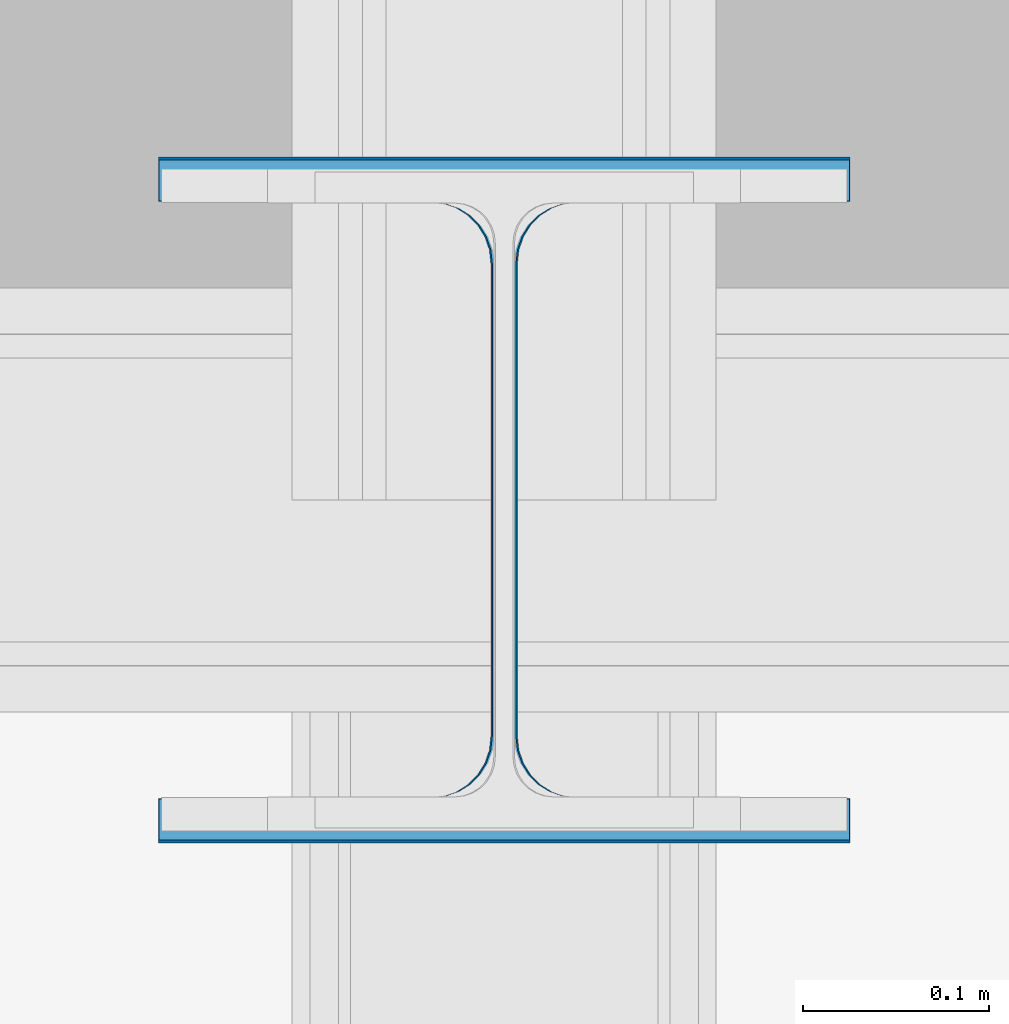
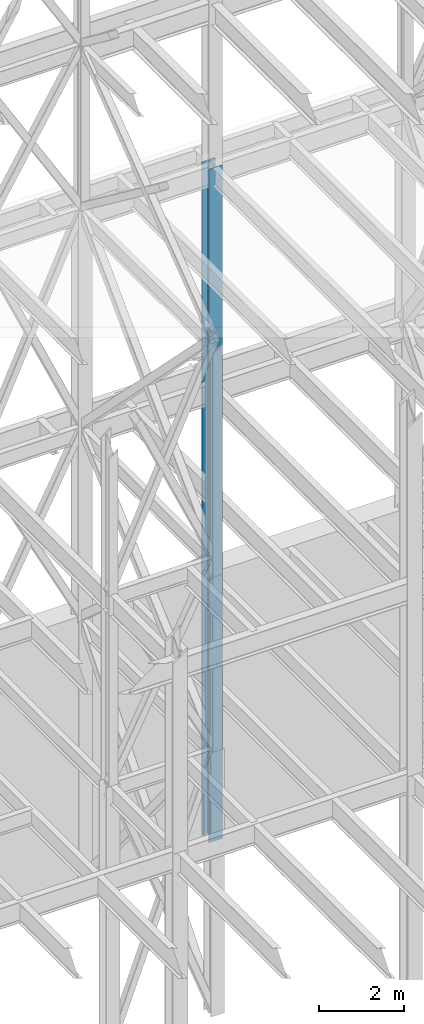
# One storey, part 101 of 150: 2 columns.
"""IFC2X3 building model written with IfcOpenShell, lengths in millimetres."""

from ifc_helpers import new_model, si_unit, frame, origin_with_axes, origin_2d_with_axis, place, context, subcontext, project, spatial, i_section, extrude, material, type_object, element, save


model = new_model("IFC2X3")

# Units and contexts
model_context = context("Model", 3, precision=1e-05, world=origin_with_axes())
body_context = subcontext(model_context, "Body", "Model", "MODEL_VIEW")
ifc_project = project(units=[si_unit("LENGTHUNIT", "METRE", prefix="MILLI"), si_unit("AREAUNIT", "SQUARE_METRE"), si_unit("VOLUMEUNIT", "CUBIC_METRE"), si_unit("MASSUNIT", "GRAM", prefix="KILO"), si_unit("TIMEUNIT", "SECOND"), si_unit("PLANEANGLEUNIT", "RADIAN"), si_unit("SOLIDANGLEUNIT", "STERADIAN"), si_unit("THERMODYNAMICTEMPERATUREUNIT", "DEGREE_CELSIUS"), si_unit("LUMINOUSINTENSITYUNIT", "LUMEN")], contexts=[model_context])

# Site, building, storey
site_placement = place(None, origin_with_axes())
site = spatial("IfcSite", under=ifc_project, at=site_placement, CompositionType="ELEMENT")
building_placement = place(site_placement, origin_with_axes())
building = spatial("IfcBuilding", under=site, at=building_placement, Name="Undefined", CompositionType="ELEMENT")
storey_placement = place(building_placement, origin_with_axes())
storey = spatial("IfcBuildingStorey", under=building, at=storey_placement, Name="Undefined", CompositionType="ELEMENT", Elevation=0.0)

# Columns
ifc_material = material(Name="STEEL/A992")
column_type_1 = type_object("IfcColumnType", Name="W14X109", PredefinedType="NOTDEFINED")
column_1_placement = place(storey_placement, frame((69392.8, 31877.0, 23774.4), z_axis=(0.0, 0.0, 1.0), x_axis=(1.0, 0.0, 0.0)))
element("IfcColumn", 1, at=column_1_placement, inside=storey, type_object=column_type_1, material=ifc_material, Name="COLUMN", ObjectType="W14X109", context=body_context, shape_type="SweptSolid", body=[
    extrude(i_section(OverallWidth=370.84, OverallDepth=365.125, WebThickness=12.6999, FlangeThickness=21.844, FilletRadius=33.7184, at=origin_2d_with_axis()), frame((0.0, 0.0, 11811.0), z_axis=(0.0, 0.0, -1.0), x_axis=(-1.0, 0.0, 0.0)), (0.0, 0.0, 1.0), 11811.0),
])
column_type_2 = type_object("IfcColumnType", Name="W14X120", PredefinedType="NOTDEFINED")
column_2_placement = place(storey_placement, frame((69392.8, 31877.0, 16154.4), z_axis=(0.0, 0.0, 1.0), x_axis=(1.0, 0.0, 0.0)))
element("IfcColumn", 2, at=column_2_placement, inside=storey, type_object=column_type_2, material=ifc_material, Name="COLUMN", ObjectType="W14X120", context=body_context, shape_type="SweptSolid", body=[
    extrude(i_section(OverallWidth=371.475, OverallDepth=368.3, WebThickness=14.2875, FlangeThickness=23.876, FilletRadius=33.274, at=origin_2d_with_axis()), frame((0.0, 0.0, 7620.0), z_axis=(0.0, 0.0, -1.0), x_axis=(-1.0, 0.0, 0.0)), (0.0, 0.0, 1.0), 7620.0),
])

save(model, "model.ifc")
